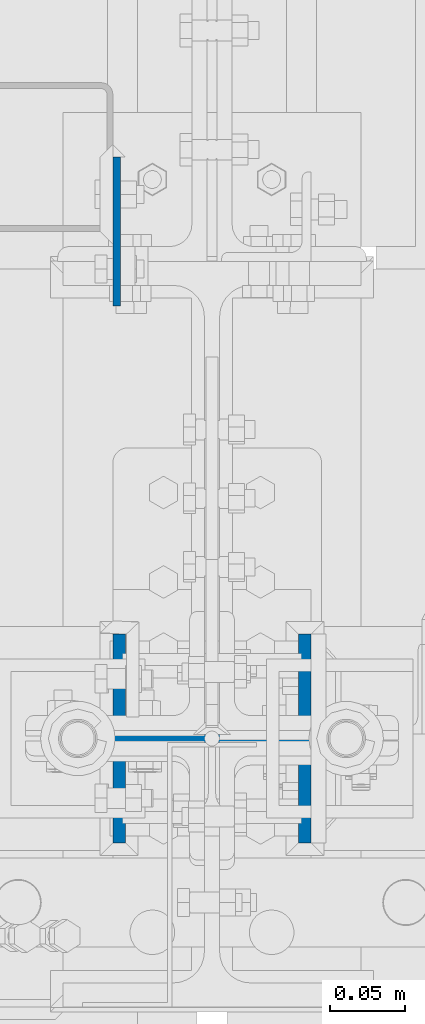
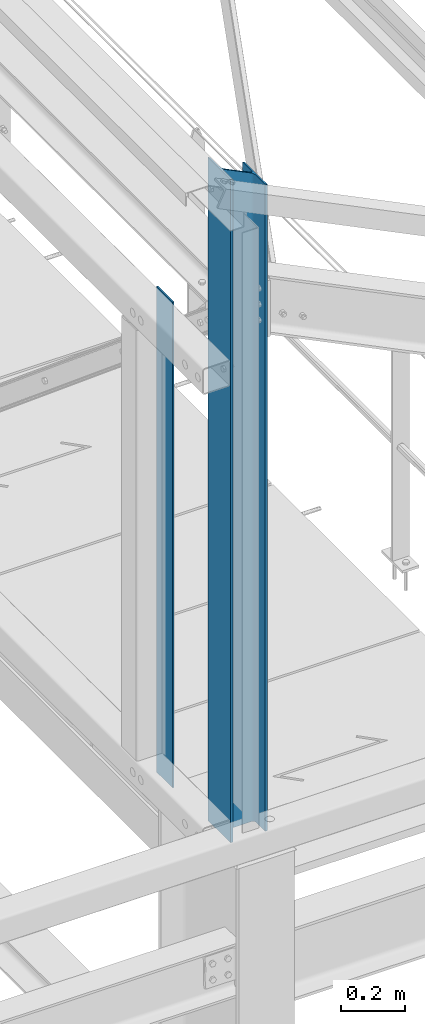
# One storey, part 15 of 496: 2 columns, 2 elements without a shape of their own.
"""IFC2X3 building model written with IfcOpenShell, lengths in millimetres."""

from ifc_helpers import new_model, si_unit, frame, origin_with_axes, origin_2d_with_axis, place, context, subcontext, project, spatial, rectangle, i_section, extrude, clip, halfspace, material, type_object, element, aggregate, save


model = new_model("IFC2X3")

# Units and contexts
model_context = context("Model", 3, precision=1e-05, world=origin_with_axes())
body_context = subcontext(model_context, "Body", "Model", "MODEL_VIEW")
ifc_project = project(units=[si_unit("LENGTHUNIT", "METRE", prefix="MILLI"), si_unit("AREAUNIT", "SQUARE_METRE"), si_unit("VOLUMEUNIT", "CUBIC_METRE"), si_unit("MASSUNIT", "GRAM", prefix="KILO"), si_unit("TIMEUNIT", "SECOND"), si_unit("PLANEANGLEUNIT", "RADIAN"), si_unit("SOLIDANGLEUNIT", "STERADIAN"), si_unit("THERMODYNAMICTEMPERATUREUNIT", "DEGREE_CELSIUS"), si_unit("LUMINOUSINTENSITYUNIT", "LUMEN")], contexts=[model_context])

# Site, building, storey
site_placement = place(None, origin_with_axes())
site = spatial("IfcSite", under=ifc_project, at=site_placement, CompositionType="ELEMENT")
building_placement = place(site_placement, origin_with_axes())
building = spatial("IfcBuilding", under=site, at=building_placement, Name="Undefined", CompositionType="ELEMENT")
storey_placement = place(building_placement, origin_with_axes())
storey = spatial("IfcBuildingStorey", under=building, at=storey_placement, Name="Undefined", CompositionType="ELEMENT", Elevation=0.0)

# Assembly, column
assembly_1_placement = place(storey_placement, origin_with_axes())
assembly_1 = element("IfcElementAssembly", 1, at=assembly_1_placement, inside=storey, Name="MONTANT", AssemblyPlace="NOTDEFINED", PredefinedType="NOTDEFINED")
ifc_material_1 = material(Name="Undefined/S275-E28")
column_type_1 = type_object("IfcColumnType", Name="HEA140", PredefinedType="NOTDEFINED")
column_1_placement = place(assembly_1_placement, frame((34280.0, 0.0, 8460.0), z_axis=(0.0, 0.0, 1.0), x_axis=(-1.0, 0.0, 0.0)))
column_1 = element("IfcColumn", 2, at=column_1_placement, type_object=column_type_1, material=ifc_material_1, Name="MONTANT", ObjectType="HEA140", context=body_context, shape_type="Clipping", body=[
    clip(extrude(i_section(OverallWidth=140.0, OverallDepth=133.0, WebThickness=5.5, FlangeThickness=8.5, FilletRadius=12.0, at=origin_2d_with_axis()), frame((0.0, 0.0, 2530.84), z_axis=(0.0, 0.0, -1.0), x_axis=(0.0, 1.0, 0.0)), (0.0, 0.0, 1.0), 2530.84), halfspace(frame((-66.5, 69.9999999999991, 2454.3071165161), z_axis=(-0.441220937981244, -6.28179308850765e-09, 0.89739850896185), x_axis=(0.89739850896185, 0.0, 0.441220937981244)), False)),
])
aggregate(assembly_1, [column_1])

assembly_2_placement = place(storey_placement, origin_with_axes())
assembly_2 = element("IfcElementAssembly", 3, at=assembly_2_placement, inside=storey, Name="MONTANT", AssemblyPlace="NOTDEFINED", PredefinedType="NOTDEFINED")
ifc_material_2 = material(Name="Undefined/S235-E24")
column_type_2 = type_object("IfcColumnType", PredefinedType="NOTDEFINED")
column_2_placement = place(assembly_2_placement, frame((34215.9999999811, 340.000158152034, 8450.0), z_axis=(0.0, 0.0, 1.0), x_axis=(0.0, -1.0, 0.0)))
column_2 = element("IfcColumn", 4, at=column_2_placement, type_object=column_type_2, material=ifc_material_2, context=body_context, shape_type="SweptSolid", body=[
    extrude(rectangle(XDim=5.0, YDim=100.0, at=origin_2d_with_axis()), frame((0.0, 0.0, 1845.0), z_axis=(0.0, 0.0, -1.0), x_axis=(0.0, 1.0, 0.0)), (0.0, 0.0, 1.0), 1845.0),
])
aggregate(assembly_2, [column_2])

save(model, "model.ifc")
